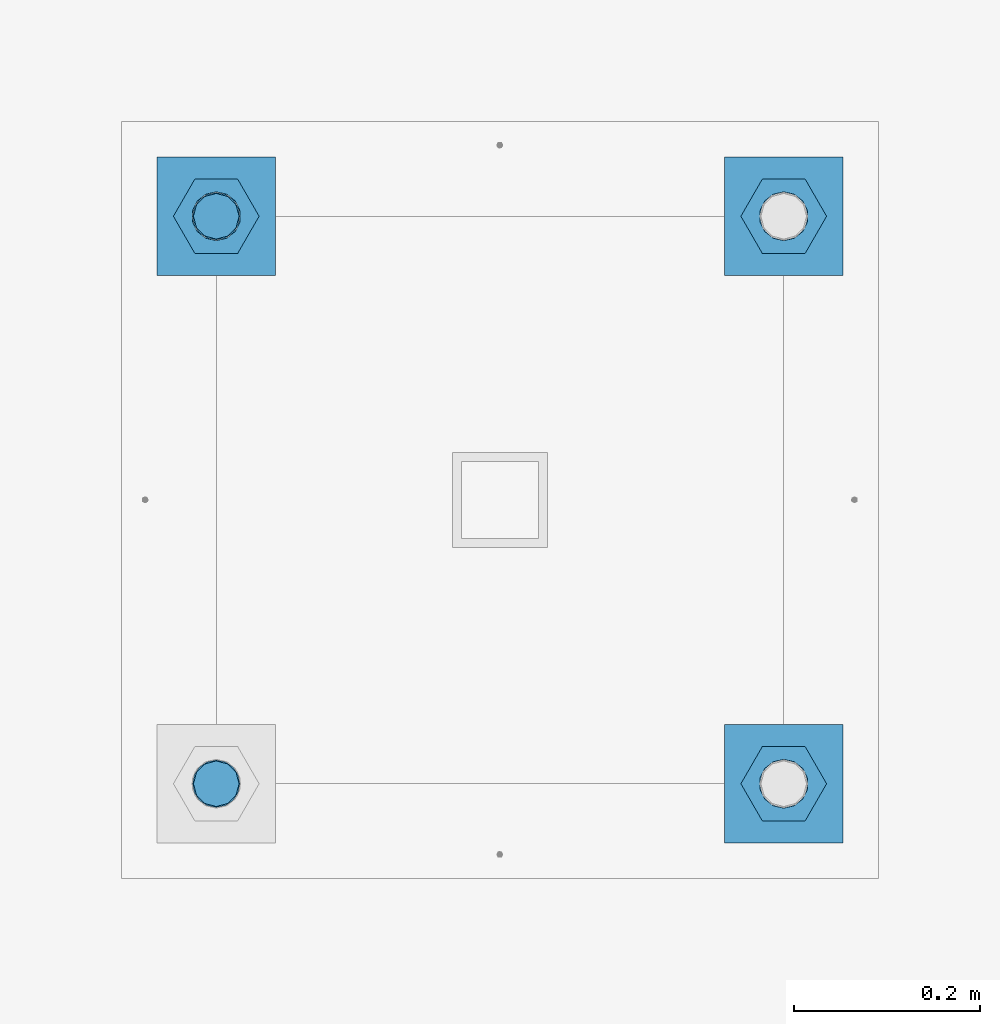
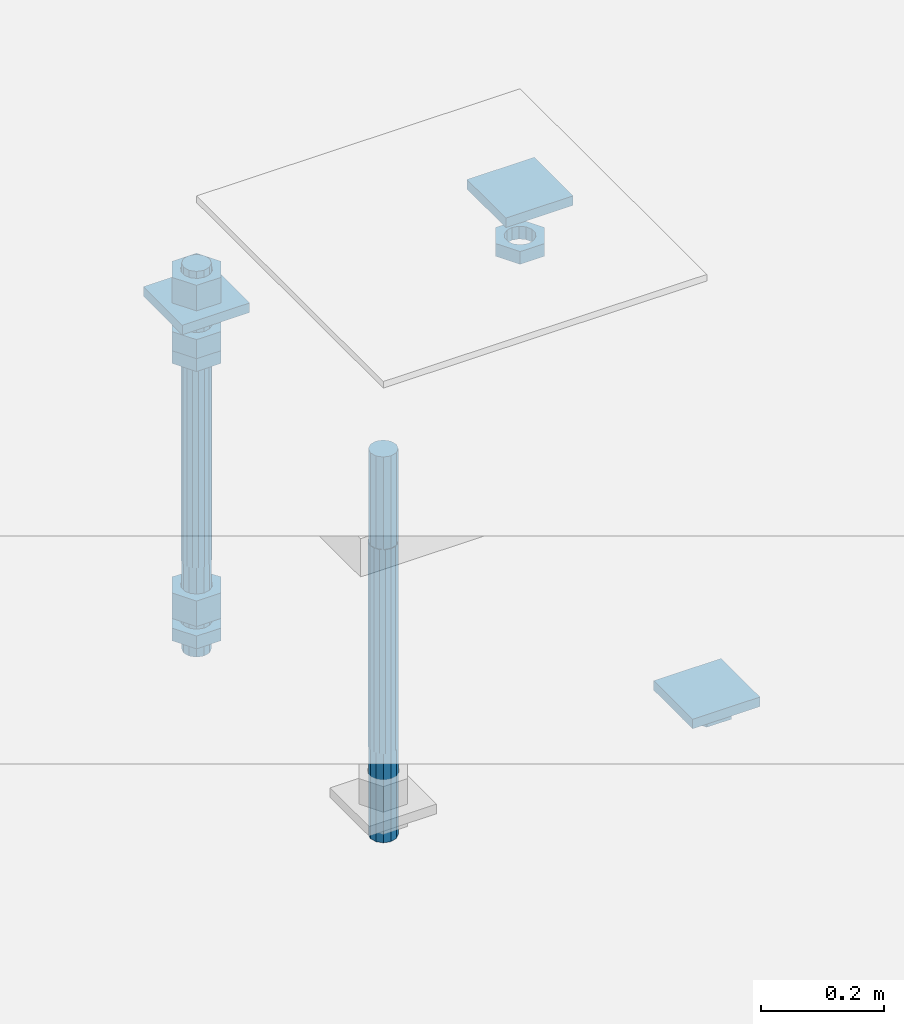
# One storey, part 2734 of 3843: 12 beams, 1 element without a shape of its own.
"""IFC2X3 building model written with IfcOpenShell, lengths in millimetres."""

from ifc_helpers import new_model, si_unit, frame, origin_with_axes, place, context, subcontext, project, spatial, faceted_brep, material, type_object, element, aggregate, save


model = new_model("IFC2X3")

# Units and contexts
model_context = context("Model", 3, precision=1e-05, world=origin_with_axes())
body_context = subcontext(model_context, "Body", "Model", "MODEL_VIEW")
ifc_project = project(units=[si_unit("LENGTHUNIT", "METRE", prefix="MILLI"), si_unit("AREAUNIT", "SQUARE_METRE"), si_unit("VOLUMEUNIT", "CUBIC_METRE"), si_unit("MASSUNIT", "GRAM", prefix="KILO"), si_unit("TIMEUNIT", "SECOND"), si_unit("PLANEANGLEUNIT", "RADIAN"), si_unit("SOLIDANGLEUNIT", "STERADIAN"), si_unit("THERMODYNAMICTEMPERATUREUNIT", "DEGREE_CELSIUS"), si_unit("LUMINOUSINTENSITYUNIT", "LUMEN")], contexts=[model_context])

# Site, building, storey
site_placement = place(None, origin_with_axes())
site = spatial("IfcSite", under=ifc_project, at=site_placement, CompositionType="ELEMENT")
building_placement = place(site_placement, origin_with_axes())
building = spatial("IfcBuilding", under=site, at=building_placement, Name="Undefined", CompositionType="ELEMENT")
storey_placement = place(building_placement, origin_with_axes())
storey = spatial("IfcBuildingStorey", under=building, at=storey_placement, Name="Undefined", CompositionType="ELEMENT", Elevation=0.0)

# Assembly, beams
assembly_placement = place(storey_placement, origin_with_axes())
assembly = element("IfcElementAssembly", 1, at=assembly_placement, inside=storey, Name="TEMPLATE", AssemblyPlace="NOTDEFINED", PredefinedType="RIGID_FRAME")
ifc_material_1 = material(Name="STEEL/A36")
beam_type_1 = type_object("IfcBeamType", PredefinedType="NOTDEFINED")
beam_1_placement = place(assembly_placement, frame((115798.6, 38798.5000015259, 29873.575), z_axis=(1.0, 0.0, 0.0), x_axis=(0.0, 1.0, 0.0)))
beam_1 = element("IfcBeam", 2, at=beam_1_placement, type_object=beam_type_1, material=ifc_material_1, Name="WASHER_PLATE", context=body_context, shape_type="Brep", body=[
    faceted_brep([(0.0, 9.52500000000146, -63.5), (0.0, 9.52500000000146, 63.5), (127.0, 9.52500000000146, 63.5), (127.0, 9.52500000000146, -63.5), (0.0, -9.52500000000146, 63.5), (127.0, -9.52500000000146, 63.5), (0.0, -9.52500000000146, -63.5), (127.0, -9.52500000000146, -63.5)], [[[0, 1, 2, 3]], [[1, 4, 5, 2]], [[4, 6, 7, 5]], [[6, 0, 3, 7]], [[5, 7, 3, 2]], [[6, 4, 1, 0]]]),
])
beam_2_placement = place(assembly_placement, frame((116408.2, 38798.5000015259, 29873.575), z_axis=(1.0, 0.0, 0.0), x_axis=(0.0, 1.0, 0.0)))
beam_2 = element("IfcBeam", 3, at=beam_2_placement, type_object=beam_type_1, material=ifc_material_1, Name="WASHER_PLATE", context=body_context, shape_type="Brep", body=[
    faceted_brep([(0.0, 9.52500000000146, -63.5), (0.0, 9.52500000000146, 63.5), (127.0, 9.52500000000146, 63.5), (127.0, 9.52500000000146, -63.5), (0.0, -9.52500000000146, 63.5), (127.0, -9.52500000000146, 63.5), (0.0, -9.52500000000146, -63.5), (127.0, -9.52500000000146, -63.5)], [[[0, 1, 2, 3]], [[1, 4, 5, 2]], [[4, 6, 7, 5]], [[6, 0, 3, 7]], [[5, 7, 3, 2]], [[6, 4, 1, 0]]]),
])
beam_3_placement = place(assembly_placement, frame((116408.2, 38188.9000015259, 29244.925), z_axis=(1.0, 0.0, 0.0), x_axis=(0.0, 1.0, 0.0)))
beam_3 = element("IfcBeam", 4, at=beam_3_placement, type_object=beam_type_1, material=ifc_material_1, Name="WASHER_PLATE", context=body_context, shape_type="Brep", body=[
    faceted_brep([(0.0, 9.52500000000146, -63.5), (0.0, 9.52500000000146, 63.5), (127.0, 9.52500000000146, 63.5), (127.0, 9.52500000000146, -63.5), (0.0, -9.52500000000146, 63.5), (127.0, -9.52500000000146, 63.5), (0.0, -9.52500000000146, -63.5), (127.0, -9.52500000000146, -63.5)], [[[0, 1, 2, 3]], [[1, 4, 5, 2]], [[4, 6, 7, 5]], [[6, 0, 3, 7]], [[5, 7, 3, 2]], [[6, 4, 1, 0]]]),
])
beam_type_2 = type_object("IfcBeamType", Name="2_HALF_NUT", PredefinedType="NOTDEFINED")
beam_4_placement = place(assembly_placement, frame((115798.6, 38862.0000015259, 29787.85), z_axis=(0.0, 1.0, 0.0), x_axis=(0.0, 0.0, -1.0)))
beam_4 = element("IfcBeam", 5, at=beam_4_placement, type_object=beam_type_2, material=ifc_material_1, Name="NUT", ObjectType="2_HALF_NUT", context=body_context, shape_type="Brep", body=[
    faceted_brep([(0.0, -46.0369987487793, 0.0), (0.0, -23.0184993743896, -39.869213104248), (25.4000000000015, -23.0184993743896, -39.869213104248), (25.4000000000015, -46.0369987487793, 0.0), (0.0, 23.0184993743896, -39.869213104248), (25.4000000000015, 23.0184993743896, -39.869213104248), (0.0, 46.0369987487793, 0.0), (25.4000000000015, 46.0369987487793, 0.0), (0.0, 23.0184993743896, 39.869213104248), (25.4000000000015, 23.0184993743896, 39.869213104248), (0.0, -23.0184993743896, 39.869213104248), (25.4000000000015, -23.0184993743896, 39.869213104248), (0.0, 0.0, 26.1940002441406), (0.0, 11.3650617044477, 23.5999013092805), (25.4000000000015, 11.3650617044477, 23.5999013092805), (25.4000000000015, 0.0, 26.1940002441406), (0.0, 20.4791109456419, 16.3316083006721), (25.4000000000015, 20.4791109456419, 16.3316083006721), (0.0, 25.5370200498292, 5.82867859874386), (25.4000000000015, 25.5370200498292, 5.82867859874386), (0.0, 25.5370200498292, -5.82867859874386), (25.4000000000015, 25.5370200498292, -5.82867859874386), (0.0, 20.4791109456419, -16.3316083006721), (25.4000000000015, 20.4791109456419, -16.3316083006721), (0.0, 11.3650617044477, -23.5999013092805), (25.4000000000015, 11.3650617044477, -23.5999013092805), (0.0, 0.0, -26.1940002441406), (25.4000000000015, 0.0, -26.1940002441406), (0.0, -11.3650617044477, -23.5999013092805), (25.4000000000015, -11.3650617044477, -23.5999013092805), (0.0, -20.4791109456419, -16.3316083006721), (25.4000000000015, -20.4791109456419, -16.3316083006721), (0.0, -25.5370200498292, -5.82867859874386), (25.4000000000015, -25.5370200498292, -5.82867859874386), (0.0, -25.5370200498292, 5.82867859874386), (25.4000000000015, -25.5370200498292, 5.82867859874386), (0.0, -20.4791109456419, 16.3316083006721), (25.4000000000015, -20.4791109456419, 16.3316083006721), (0.0, -11.3650617044477, 23.5999013092805), (25.4000000000015, -11.3650617044477, 23.5999013092805)], [[[0, 1, 2, 3]], [[1, 4, 5, 2]], [[4, 6, 7, 5]], [[6, 8, 9, 7]], [[8, 10, 11, 9]], [[10, 0, 3, 11]], [[12, 13, 14, 15]], [[13, 16, 17, 14]], [[16, 18, 19, 17]], [[18, 20, 21, 19]], [[20, 22, 23, 21]], [[22, 24, 25, 23]], [[24, 26, 27, 25]], [[26, 28, 29, 27]], [[28, 30, 31, 29]], [[30, 32, 33, 31]], [[32, 34, 35, 33]], [[34, 36, 37, 35]], [[36, 38, 39, 37]], [[38, 12, 15, 39]], [[5, 7, 9, 11, 3, 2], [17, 19, 21, 23, 25, 27, 29, 31, 33, 35, 37, 39, 15, 14]], [[10, 8, 6, 4, 1, 0], [38, 36, 34, 32, 30, 28, 26, 24, 22, 20, 18, 16, 13, 12]]]),
])
beam_5_placement = place(assembly_placement, frame((116408.2, 38862.0000015259, 29787.85), z_axis=(0.0, 1.0, 0.0), x_axis=(0.0, 0.0, -1.0)))
beam_5 = element("IfcBeam", 6, at=beam_5_placement, type_object=beam_type_2, material=ifc_material_1, Name="NUT", ObjectType="2_HALF_NUT", context=body_context, shape_type="Brep", body=[
    faceted_brep([(0.0, -46.0369987487793, 0.0), (0.0, -23.0184993743896, -39.869213104248), (25.4000000000015, -23.0184993743896, -39.869213104248), (25.4000000000015, -46.0369987487793, 0.0), (0.0, 23.0184993743896, -39.869213104248), (25.4000000000015, 23.0184993743896, -39.869213104248), (0.0, 46.0369987487793, 0.0), (25.4000000000015, 46.0369987487793, 0.0), (0.0, 23.0184993743896, 39.869213104248), (25.4000000000015, 23.0184993743896, 39.869213104248), (0.0, -23.0184993743896, 39.869213104248), (25.4000000000015, -23.0184993743896, 39.869213104248), (0.0, 0.0, 26.1940002441406), (0.0, 11.3650617044477, 23.5999013092805), (25.4000000000015, 11.3650617044477, 23.5999013092805), (25.4000000000015, 0.0, 26.1940002441406), (0.0, 20.4791109456419, 16.3316083006721), (25.4000000000015, 20.4791109456419, 16.3316083006721), (0.0, 25.5370200498292, 5.82867859874386), (25.4000000000015, 25.5370200498292, 5.82867859874386), (0.0, 25.5370200498292, -5.82867859874386), (25.4000000000015, 25.5370200498292, -5.82867859874386), (0.0, 20.4791109456419, -16.3316083006721), (25.4000000000015, 20.4791109456419, -16.3316083006721), (0.0, 11.3650617044477, -23.5999013092805), (25.4000000000015, 11.3650617044477, -23.5999013092805), (0.0, 0.0, -26.1940002441406), (25.4000000000015, 0.0, -26.1940002441406), (0.0, -11.3650617044477, -23.5999013092805), (25.4000000000015, -11.3650617044477, -23.5999013092805), (0.0, -20.4791109456419, -16.3316083006721), (25.4000000000015, -20.4791109456419, -16.3316083006721), (0.0, -25.5370200498292, -5.82867859874386), (25.4000000000015, -25.5370200498292, -5.82867859874386), (0.0, -25.5370200498292, 5.82867859874386), (25.4000000000015, -25.5370200498292, 5.82867859874386), (0.0, -20.4791109456419, 16.3316083006721), (25.4000000000015, -20.4791109456419, 16.3316083006721), (0.0, -11.3650617044477, 23.5999013092805), (25.4000000000015, -11.3650617044477, 23.5999013092805)], [[[0, 1, 2, 3]], [[1, 4, 5, 2]], [[4, 6, 7, 5]], [[6, 8, 9, 7]], [[8, 10, 11, 9]], [[10, 0, 3, 11]], [[12, 13, 14, 15]], [[13, 16, 17, 14]], [[16, 18, 19, 17]], [[18, 20, 21, 19]], [[20, 22, 23, 21]], [[22, 24, 25, 23]], [[24, 26, 27, 25]], [[26, 28, 29, 27]], [[28, 30, 31, 29]], [[30, 32, 33, 31]], [[32, 34, 35, 33]], [[34, 36, 37, 35]], [[36, 38, 39, 37]], [[38, 12, 15, 39]], [[5, 7, 9, 11, 3, 2], [17, 19, 21, 23, 25, 27, 29, 31, 33, 35, 37, 39, 15, 14]], [[10, 8, 6, 4, 1, 0], [38, 36, 34, 32, 30, 28, 26, 24, 22, 20, 18, 16, 13, 12]]]),
])
beam_6_placement = place(assembly_placement, frame((116408.2, 38252.4000015259, 29235.4), z_axis=(0.0, 1.0, 0.0), x_axis=(0.0, 0.0, -1.0)))
beam_6 = element("IfcBeam", 7, at=beam_6_placement, type_object=beam_type_2, material=ifc_material_1, Name="NUT", ObjectType="2_HALF_NUT", context=body_context, shape_type="Brep", body=[
    faceted_brep([(0.0, -46.0369987487793, 0.0), (0.0, -23.0184993743896, -39.869213104248), (25.4000000000015, -23.0184993743896, -39.869213104248), (25.4000000000015, -46.0369987487793, 0.0), (0.0, 23.0184993743896, -39.869213104248), (25.4000000000015, 23.0184993743896, -39.869213104248), (0.0, 46.0369987487793, 0.0), (25.4000000000015, 46.0369987487793, 0.0), (0.0, 23.0184993743896, 39.869213104248), (25.4000000000015, 23.0184993743896, 39.869213104248), (0.0, -23.0184993743896, 39.869213104248), (25.4000000000015, -23.0184993743896, 39.869213104248), (0.0, 0.0, 26.1940002441406), (0.0, 11.3650617044477, 23.5999013092805), (25.4000000000015, 11.3650617044477, 23.5999013092805), (25.4000000000015, 0.0, 26.1940002441406), (0.0, 20.4791109456419, 16.3316083006721), (25.4000000000015, 20.4791109456419, 16.3316083006721), (0.0, 25.5370200498292, 5.82867859874386), (25.4000000000015, 25.5370200498292, 5.82867859874386), (0.0, 25.5370200498292, -5.82867859874386), (25.4000000000015, 25.5370200498292, -5.82867859874386), (0.0, 20.4791109456419, -16.3316083006721), (25.4000000000015, 20.4791109456419, -16.3316083006721), (0.0, 11.3650617044477, -23.5999013092805), (25.4000000000015, 11.3650617044477, -23.5999013092805), (0.0, 0.0, -26.1940002441406), (25.4000000000015, 0.0, -26.1940002441406), (0.0, -11.3650617044477, -23.5999013092805), (25.4000000000015, -11.3650617044477, -23.5999013092805), (0.0, -20.4791109456419, -16.3316083006721), (25.4000000000015, -20.4791109456419, -16.3316083006721), (0.0, -25.5370200498292, -5.82867859874386), (25.4000000000015, -25.5370200498292, -5.82867859874386), (0.0, -25.5370200498292, 5.82867859874386), (25.4000000000015, -25.5370200498292, 5.82867859874386), (0.0, -20.4791109456419, 16.3316083006721), (25.4000000000015, -20.4791109456419, 16.3316083006721), (0.0, -11.3650617044477, 23.5999013092805), (25.4000000000015, -11.3650617044477, 23.5999013092805)], [[[0, 1, 2, 3]], [[1, 4, 5, 2]], [[4, 6, 7, 5]], [[6, 8, 9, 7]], [[8, 10, 11, 9]], [[10, 0, 3, 11]], [[12, 13, 14, 15]], [[13, 16, 17, 14]], [[16, 18, 19, 17]], [[18, 20, 21, 19]], [[20, 22, 23, 21]], [[22, 24, 25, 23]], [[24, 26, 27, 25]], [[26, 28, 29, 27]], [[28, 30, 31, 29]], [[30, 32, 33, 31]], [[32, 34, 35, 33]], [[34, 36, 37, 35]], [[36, 38, 39, 37]], [[38, 12, 15, 39]], [[5, 7, 9, 11, 3, 2], [17, 19, 21, 23, 25, 27, 29, 31, 33, 35, 37, 39, 15, 14]], [[10, 8, 6, 4, 1, 0], [38, 36, 34, 32, 30, 28, 26, 24, 22, 20, 18, 16, 13, 12]]]),
])
beam_7_placement = place(assembly_placement, frame((115798.6, 38862.0000015259, 29235.4), z_axis=(0.0, 1.0, 0.0), x_axis=(0.0, 0.0, -1.0)))
beam_7 = element("IfcBeam", 8, at=beam_7_placement, type_object=beam_type_2, material=ifc_material_1, Name="NUT", ObjectType="2_HALF_NUT", context=body_context, shape_type="Brep", body=[
    faceted_brep([(0.0, -46.0369987487793, 0.0), (0.0, -23.0184993743896, -39.869213104248), (25.4000000000015, -23.0184993743896, -39.869213104248), (25.4000000000015, -46.0369987487793, 0.0), (0.0, 23.0184993743896, -39.869213104248), (25.4000000000015, 23.0184993743896, -39.869213104248), (0.0, 46.0369987487793, 0.0), (25.4000000000015, 46.0369987487793, 0.0), (0.0, 23.0184993743896, 39.869213104248), (25.4000000000015, 23.0184993743896, 39.869213104248), (0.0, -23.0184993743896, 39.869213104248), (25.4000000000015, -23.0184993743896, 39.869213104248), (0.0, 0.0, 26.1940002441406), (0.0, 11.3650617044477, 23.5999013092805), (25.4000000000015, 11.3650617044477, 23.5999013092805), (25.4000000000015, 0.0, 26.1940002441406), (0.0, 20.4791109456419, 16.3316083006721), (25.4000000000015, 20.4791109456419, 16.3316083006721), (0.0, 25.5370200498292, 5.82867859874386), (25.4000000000015, 25.5370200498292, 5.82867859874386), (0.0, 25.5370200498292, -5.82867859874386), (25.4000000000015, 25.5370200498292, -5.82867859874386), (0.0, 20.4791109456419, -16.3316083006721), (25.4000000000015, 20.4791109456419, -16.3316083006721), (0.0, 11.3650617044477, -23.5999013092805), (25.4000000000015, 11.3650617044477, -23.5999013092805), (0.0, 0.0, -26.1940002441406), (25.4000000000015, 0.0, -26.1940002441406), (0.0, -11.3650617044477, -23.5999013092805), (25.4000000000015, -11.3650617044477, -23.5999013092805), (0.0, -20.4791109456419, -16.3316083006721), (25.4000000000015, -20.4791109456419, -16.3316083006721), (0.0, -25.5370200498292, -5.82867859874386), (25.4000000000015, -25.5370200498292, -5.82867859874386), (0.0, -25.5370200498292, 5.82867859874386), (25.4000000000015, -25.5370200498292, 5.82867859874386), (0.0, -20.4791109456419, 16.3316083006721), (25.4000000000015, -20.4791109456419, 16.3316083006721), (0.0, -11.3650617044477, 23.5999013092805), (25.4000000000015, -11.3650617044477, 23.5999013092805)], [[[0, 1, 2, 3]], [[1, 4, 5, 2]], [[4, 6, 7, 5]], [[6, 8, 9, 7]], [[8, 10, 11, 9]], [[10, 0, 3, 11]], [[12, 13, 14, 15]], [[13, 16, 17, 14]], [[16, 18, 19, 17]], [[18, 20, 21, 19]], [[20, 22, 23, 21]], [[22, 24, 25, 23]], [[24, 26, 27, 25]], [[26, 28, 29, 27]], [[28, 30, 31, 29]], [[30, 32, 33, 31]], [[32, 34, 35, 33]], [[34, 36, 37, 35]], [[36, 38, 39, 37]], [[38, 12, 15, 39]], [[5, 7, 9, 11, 3, 2], [17, 19, 21, 23, 25, 27, 29, 31, 33, 35, 37, 39, 15, 14]], [[10, 8, 6, 4, 1, 0], [38, 36, 34, 32, 30, 28, 26, 24, 22, 20, 18, 16, 13, 12]]]),
])
beam_type_3 = type_object("IfcBeamType", Name="2_HEAVY_HEX_NUT", PredefinedType="NOTDEFINED")
beam_8_placement = place(assembly_placement, frame((115798.6, 38862.0000015259, 29825.95), z_axis=(0.0, 1.0, 0.0), x_axis=(0.0, 0.0, -1.0)))
beam_8 = element("IfcBeam", 9, at=beam_8_placement, type_object=beam_type_3, material=ifc_material_1, Name="NUT", ObjectType="2_HEAVY_HEX_NUT", context=body_context, shape_type="Brep", body=[
    faceted_brep([(0.0, -46.0369987487793, 0.0), (0.0, -23.0184993743896, -39.869213104248), (38.0999999999985, -23.0184993743896, -39.869213104248), (38.0999999999985, -46.0369987487793, 0.0), (0.0, 23.0184993743896, -39.869213104248), (38.0999999999985, 23.0184993743896, -39.869213104248), (0.0, 46.0369987487793, 0.0), (38.0999999999985, 46.0369987487793, 0.0), (0.0, 23.0184993743896, 39.869213104248), (38.0999999999985, 23.0184993743896, 39.869213104248), (0.0, -23.0184993743896, 39.869213104248), (38.0999999999985, -23.0184993743896, 39.869213104248), (0.0, 0.0, 26.1940002441406), (0.0, 11.3650617044477, 23.5999013092805), (38.0999999999985, 11.3650617044477, 23.5999013092805), (38.0999999999985, 0.0, 26.1940002441406), (0.0, 20.4791109456419, 16.3316083006721), (38.0999999999985, 20.4791109456419, 16.3316083006721), (0.0, 25.5370200498292, 5.82867859874386), (38.0999999999985, 25.5370200498292, 5.82867859874386), (0.0, 25.5370200498292, -5.82867859874386), (38.0999999999985, 25.5370200498292, -5.82867859874386), (0.0, 20.4791109456419, -16.3316083006721), (38.0999999999985, 20.4791109456419, -16.3316083006721), (0.0, 11.3650617044477, -23.5999013092805), (38.0999999999985, 11.3650617044477, -23.5999013092805), (0.0, 0.0, -26.1940002441406), (38.0999999999985, 0.0, -26.1940002441406), (0.0, -11.3650617044477, -23.5999013092805), (38.0999999999985, -11.3650617044477, -23.5999013092805), (0.0, -20.4791109456419, -16.3316083006721), (38.0999999999985, -20.4791109456419, -16.3316083006721), (0.0, -25.5370200498292, -5.82867859874386), (38.0999999999985, -25.5370200498292, -5.82867859874386), (0.0, -25.5370200498292, 5.82867859874386), (38.0999999999985, -25.5370200498292, 5.82867859874386), (0.0, -20.4791109456419, 16.3316083006721), (38.0999999999985, -20.4791109456419, 16.3316083006721), (0.0, -11.3650617044477, 23.5999013092805), (38.0999999999985, -11.3650617044477, 23.5999013092805)], [[[0, 1, 2, 3]], [[1, 4, 5, 2]], [[4, 6, 7, 5]], [[6, 8, 9, 7]], [[8, 10, 11, 9]], [[10, 0, 3, 11]], [[12, 13, 14, 15]], [[13, 16, 17, 14]], [[16, 18, 19, 17]], [[18, 20, 21, 19]], [[20, 22, 23, 21]], [[22, 24, 25, 23]], [[24, 26, 27, 25]], [[26, 28, 29, 27]], [[28, 30, 31, 29]], [[30, 32, 33, 31]], [[32, 34, 35, 33]], [[34, 36, 37, 35]], [[36, 38, 39, 37]], [[38, 12, 15, 39]], [[5, 7, 9, 11, 3, 2], [17, 19, 21, 23, 25, 27, 29, 31, 33, 35, 37, 39, 15, 14]], [[10, 8, 6, 4, 1, 0], [38, 36, 34, 32, 30, 28, 26, 24, 22, 20, 18, 16, 13, 12]]]),
])
beam_9_placement = place(assembly_placement, frame((115798.6, 38862.0000015259, 29933.9), z_axis=(0.0, 1.0, 0.0), x_axis=(0.0, 0.0, -1.0)))
beam_9 = element("IfcBeam", 10, at=beam_9_placement, type_object=beam_type_3, material=ifc_material_1, Name="NUT", ObjectType="2_HEAVY_HEX_NUT", context=body_context, shape_type="Brep", body=[
    faceted_brep([(0.0, -46.0369987487793, 0.0), (0.0, -23.0184993743896, -39.869213104248), (50.7999999999993, -23.0184993743896, -39.869213104248), (50.7999999999993, -46.0369987487793, 0.0), (0.0, 23.0184993743896, -39.869213104248), (50.7999999999993, 23.0184993743896, -39.869213104248), (0.0, 46.0369987487793, 0.0), (50.7999999999993, 46.0369987487793, 0.0), (0.0, 23.0184993743896, 39.869213104248), (50.7999999999993, 23.0184993743896, 39.869213104248), (0.0, -23.0184993743896, 39.869213104248), (50.7999999999993, -23.0184993743896, 39.869213104248), (0.0, 0.0, 26.1940002441406), (0.0, 11.3650617044477, 23.5999013092805), (50.7999999999993, 11.3650617044477, 23.5999013092805), (50.7999999999993, 0.0, 26.1940002441406), (0.0, 20.4791109456419, 16.3316083006721), (50.7999999999993, 20.4791109456419, 16.3316083006721), (0.0, 25.5370200498292, 5.82867859874386), (50.7999999999993, 25.5370200498292, 5.82867859874386), (0.0, 25.5370200498292, -5.82867859874386), (50.7999999999993, 25.5370200498292, -5.82867859874386), (0.0, 20.4791109456419, -16.3316083006721), (50.7999999999993, 20.4791109456419, -16.3316083006721), (0.0, 11.3650617044477, -23.5999013092805), (50.7999999999993, 11.3650617044477, -23.5999013092805), (0.0, 0.0, -26.1940002441406), (50.7999999999993, 0.0, -26.1940002441406), (0.0, -11.3650617044477, -23.5999013092805), (50.7999999999993, -11.3650617044477, -23.5999013092805), (0.0, -20.4791109456419, -16.3316083006721), (50.7999999999993, -20.4791109456419, -16.3316083006721), (0.0, -25.5370200498292, -5.82867859874386), (50.7999999999993, -25.5370200498292, -5.82867859874386), (0.0, -25.5370200498292, 5.82867859874386), (50.7999999999993, -25.5370200498292, 5.82867859874386), (0.0, -20.4791109456419, 16.3316083006721), (50.7999999999993, -20.4791109456419, 16.3316083006721), (0.0, -11.3650617044477, 23.5999013092805), (50.7999999999993, -11.3650617044477, 23.5999013092805)], [[[0, 1, 2, 3]], [[1, 4, 5, 2]], [[4, 6, 7, 5]], [[6, 8, 9, 7]], [[8, 10, 11, 9]], [[10, 0, 3, 11]], [[12, 13, 14, 15]], [[13, 16, 17, 14]], [[16, 18, 19, 17]], [[18, 20, 21, 19]], [[20, 22, 23, 21]], [[22, 24, 25, 23]], [[24, 26, 27, 25]], [[26, 28, 29, 27]], [[28, 30, 31, 29]], [[30, 32, 33, 31]], [[32, 34, 35, 33]], [[34, 36, 37, 35]], [[36, 38, 39, 37]], [[38, 12, 15, 39]], [[5, 7, 9, 11, 3, 2], [17, 19, 21, 23, 25, 27, 29, 31, 33, 35, 37, 39, 15, 14]], [[10, 8, 6, 4, 1, 0], [38, 36, 34, 32, 30, 28, 26, 24, 22, 20, 18, 16, 13, 12]]]),
])
beam_10_placement = place(assembly_placement, frame((115798.6, 38862.0000015259, 29305.25), z_axis=(0.0, 1.0, 0.0), x_axis=(0.0, 0.0, -1.0)))
beam_10 = element("IfcBeam", 11, at=beam_10_placement, type_object=beam_type_3, material=ifc_material_1, Name="NUT", ObjectType="2_HEAVY_HEX_NUT", context=body_context, shape_type="Brep", body=[
    faceted_brep([(0.0, -46.0369987487793, 0.0), (0.0, -23.0184993743896, -39.869213104248), (50.7999999999993, -23.0184993743896, -39.869213104248), (50.7999999999993, -46.0369987487793, 0.0), (0.0, 23.0184993743896, -39.869213104248), (50.7999999999993, 23.0184993743896, -39.869213104248), (0.0, 46.0369987487793, 0.0), (50.7999999999993, 46.0369987487793, 0.0), (0.0, 23.0184993743896, 39.869213104248), (50.7999999999993, 23.0184993743896, 39.869213104248), (0.0, -23.0184993743896, 39.869213104248), (50.7999999999993, -23.0184993743896, 39.869213104248), (0.0, 0.0, 26.1940002441406), (0.0, 11.3650617044477, 23.5999013092805), (50.7999999999993, 11.3650617044477, 23.5999013092805), (50.7999999999993, 0.0, 26.1940002441406), (0.0, 20.4791109456419, 16.3316083006721), (50.7999999999993, 20.4791109456419, 16.3316083006721), (0.0, 25.5370200498292, 5.82867859874386), (50.7999999999993, 25.5370200498292, 5.82867859874386), (0.0, 25.5370200498292, -5.82867859874386), (50.7999999999993, 25.5370200498292, -5.82867859874386), (0.0, 20.4791109456419, -16.3316083006721), (50.7999999999993, 20.4791109456419, -16.3316083006721), (0.0, 11.3650617044477, -23.5999013092805), (50.7999999999993, 11.3650617044477, -23.5999013092805), (0.0, 0.0, -26.1940002441406), (50.7999999999993, 0.0, -26.1940002441406), (0.0, -11.3650617044477, -23.5999013092805), (50.7999999999993, -11.3650617044477, -23.5999013092805), (0.0, -20.4791109456419, -16.3316083006721), (50.7999999999993, -20.4791109456419, -16.3316083006721), (0.0, -25.5370200498292, -5.82867859874386), (50.7999999999993, -25.5370200498292, -5.82867859874386), (0.0, -25.5370200498292, 5.82867859874386), (50.7999999999993, -25.5370200498292, 5.82867859874386), (0.0, -20.4791109456419, 16.3316083006721), (50.7999999999993, -20.4791109456419, 16.3316083006721), (0.0, -11.3650617044477, 23.5999013092805), (50.7999999999993, -11.3650617044477, 23.5999013092805)], [[[0, 1, 2, 3]], [[1, 4, 5, 2]], [[4, 6, 7, 5]], [[6, 8, 9, 7]], [[8, 10, 11, 9]], [[10, 0, 3, 11]], [[12, 13, 14, 15]], [[13, 16, 17, 14]], [[16, 18, 19, 17]], [[18, 20, 21, 19]], [[20, 22, 23, 21]], [[22, 24, 25, 23]], [[24, 26, 27, 25]], [[26, 28, 29, 27]], [[28, 30, 31, 29]], [[30, 32, 33, 31]], [[32, 34, 35, 33]], [[34, 36, 37, 35]], [[36, 38, 39, 37]], [[38, 12, 15, 39]], [[5, 7, 9, 11, 3, 2], [17, 19, 21, 23, 25, 27, 29, 31, 33, 35, 37, 39, 15, 14]], [[10, 8, 6, 4, 1, 0], [38, 36, 34, 32, 30, 28, 26, 24, 22, 20, 18, 16, 13, 12]]]),
])
ifc_material_2 = material()
beam_type_4 = type_object("IfcBeamType", PredefinedType="NOTDEFINED")
beam_11_placement = place(assembly_placement, frame((115798.6, 38862.0000015259, 29762.45), z_axis=(0.0, 1.0, 0.0), x_axis=(0.0, 0.0, -1.0)))
beam_11 = element("IfcBeam", 12, at=beam_11_placement, type_object=beam_type_4, material=ifc_material_2, Name="ANCHOR_ROD", context=body_context, shape_type="Brep", body=[
    faceted_brep([(-184.150000000001, -21.217622392709, 12.25), (-184.150000000001, -12.2499999999854, 21.2176223927163), (-184.150000000001, 1.45519152283669e-11, 24.5), (-184.150000000001, 12.2500000000146, 21.2176223927163), (-184.150000000001, 21.2176223927381, 12.25), (-184.150000000001, 24.5000000000146, 0.0), (-184.150000000001, 21.2176223927381, -12.25), (-184.150000000001, 12.2500000000146, -21.2176223927163), (-184.150000000001, 1.45519152283669e-11, -24.5), (-184.150000000001, -12.2499999999854, -21.2176223927163), (-184.150000000001, -21.217622392709, -12.25), (-184.150000000001, -24.4999999999854, 0.0), (0.0, 24.5000000000146, 0.0), (0.0, 21.2176223927381, -12.25), (0.0, 12.2500000000146, -21.2176223927163), (0.0, 1.45519152283669e-11, -24.5), (0.0, -12.2499999999854, -21.2176223927163), (0.0, -21.217622392709, -12.25), (0.0, -24.4999999999854, 0.0), (0.0, -21.217622392709, 12.25), (0.0, -12.2499999999854, 21.2176223927163), (0.0, 1.45519152283669e-11, 24.5), (0.0, 12.2500000000146, 21.2176223927163), (0.0, 21.2176223927381, 12.25), (0.0, -23.4665401257807, 9.72015918207035), (0.0, -17.9605122421344, 17.9605122421417), (0.0, -9.72015918207762, 23.466540125788), (0.0, 0.0, 25.4000000000015), (0.0, 9.72015918207762, 23.466540125788), (0.0, 17.9605122421344, 17.9605122421417), (0.0, 23.4665401257807, 9.72015918207035), (0.0, 25.3999996185303, 0.0), (0.0, 23.4665401257807, -9.72015918207035), (0.0, 17.9605122421344, -17.9605122421417), (0.0, 9.72015918207762, -23.466540125788), (0.0, 0.0, -25.4000000000015), (0.0, -9.72015918207762, -23.466540125788), (0.0, -17.9605122421344, -17.9605122421417), (0.0, -23.4665401257807, -9.72015918207035), (0.0, -25.3999996185303, 0.0), (406.399999999998, -25.3999999999942, 0.0), (406.399999999998, -23.4665401257807, 9.72015918207035), (406.399999999998, -17.9605122421344, 17.9605122421417), (406.399999999998, -9.72015918207762, 23.466540125788), (406.399999999998, 0.0, 25.4000000000015), (406.399999999998, 9.72015918207762, 23.466540125788), (406.399999999998, 17.9605122421344, 17.9605122421417), (406.399999999998, 23.4665401257807, 9.72015918207035), (406.399999999998, 25.3999999999942, 0.0), (406.399999999998, 23.4665401257807, -9.72015918207035), (406.399999999998, 17.9605122421344, -17.9605122421417), (406.399999999998, 9.72015918207762, -23.466540125788), (406.399999999998, 0.0, -25.4000000000015), (406.399999999998, -9.72015918207762, -23.466540125788), (406.399999999998, -17.9605122421344, -17.9605122421417), (406.399999999998, -23.4665401257807, -9.72015918207035), (406.399999999998, -12.2499999999854, 21.2176223927163), (406.399999999998, 1.45519152283669e-11, 24.5), (406.399999999998, 12.2500000000146, 21.2176223927163), (406.399999999998, 21.2176223927381, 12.25), (406.399999999998, 24.5000000000146, 0.0), (406.399999999998, 21.2176223927381, -12.25), (406.399999999998, 12.2500000000146, -21.2176223927163), (406.399999999998, 1.45519152283669e-11, -24.5), (406.399999999998, -12.2499999999854, -21.2176223927163), (406.399999999998, -21.217622392709, -12.25), (406.399999999998, -24.4999999999854, 0.0), (406.399999999998, -21.217622392709, 12.25), (584.200000000001, -12.2499999999854, -21.2176223927163), (584.200000000001, 1.45519152283669e-11, -24.5), (584.200000000001, 12.2500000000146, -21.2176223927163), (584.200000000001, 21.2176223927381, -12.25), (584.200000000001, 24.5000000000146, 0.0), (584.200000000001, 21.2176223927381, 12.25), (584.200000000001, 12.2500000000146, 21.2176223927163), (584.200000000001, 1.45519152283669e-11, 24.5), (584.200000000001, -12.2499999999854, 21.2176223927163), (584.200000000001, -21.217622392709, 12.25), (584.200000000001, -24.4999999999854, 0.0), (584.200000000001, -21.217622392709, -12.25)], [[[0, 1, 2, 3, 4, 5, 6, 7, 8, 9, 10, 11]], [[6, 5, 12, 13]], [[7, 6, 13, 14]], [[8, 7, 14, 15]], [[9, 8, 15, 16]], [[10, 9, 16, 17]], [[11, 10, 17, 18]], [[0, 11, 18, 19]], [[1, 0, 19, 20]], [[2, 1, 20, 21]], [[3, 2, 21, 22]], [[4, 3, 22, 23]], [[5, 4, 23, 12]], [[24, 25, 26, 27, 28, 29, 30, 31, 32, 33, 34, 35, 36, 37, 38, 39], [22, 21, 20, 19, 18, 17, 16, 15, 14, 13, 12, 23]], [[24, 39, 40, 41]], [[25, 24, 41, 42]], [[26, 25, 42, 43]], [[27, 26, 43, 44]], [[28, 27, 44, 45]], [[29, 28, 45, 46]], [[30, 29, 46, 47]], [[31, 30, 47, 48]], [[32, 31, 48, 49]], [[33, 32, 49, 50]], [[34, 33, 50, 51]], [[35, 34, 51, 52]], [[36, 35, 52, 53]], [[37, 36, 53, 54]], [[38, 37, 54, 55]], [[39, 38, 55, 40]], [[54, 53, 52, 51, 50, 49, 48, 47, 46, 45, 44, 43, 42, 41, 40, 55], [56, 57, 58, 59, 60, 61, 62, 63, 64, 65, 66, 67]], [[68, 69, 70, 71, 72, 73, 74, 75, 76, 77, 78, 79]], [[76, 75, 57, 56]], [[77, 76, 56, 67]], [[78, 77, 67, 66]], [[79, 78, 66, 65]], [[68, 79, 65, 64]], [[69, 68, 64, 63]], [[70, 69, 63, 62]], [[71, 70, 62, 61]], [[72, 71, 61, 60]], [[73, 72, 60, 59]], [[74, 73, 59, 58]], [[75, 74, 58, 57]]]),
])
beam_12_placement = place(assembly_placement, frame((115798.6, 38252.4000015259, 29762.45), z_axis=(0.0, 1.0, 0.0), x_axis=(0.0, 0.0, -1.0)))
beam_12 = element("IfcBeam", 13, at=beam_12_placement, type_object=beam_type_4, material=ifc_material_2, Name="ANCHOR_ROD", context=body_context, shape_type="Brep", body=[
    faceted_brep([(-184.150000000001, -21.217622392709, 12.25), (-184.150000000001, -12.2499999999854, 21.2176223927163), (-184.150000000001, 1.45519152283669e-11, 24.5), (-184.150000000001, 12.2500000000146, 21.2176223927163), (-184.150000000001, 21.2176223927381, 12.25), (-184.150000000001, 24.5000000000146, 0.0), (-184.150000000001, 21.2176223927381, -12.25), (-184.150000000001, 12.2500000000146, -21.2176223927163), (-184.150000000001, 1.45519152283669e-11, -24.5), (-184.150000000001, -12.2499999999854, -21.2176223927163), (-184.150000000001, -21.217622392709, -12.25), (-184.150000000001, -24.4999999999854, 0.0), (0.0, 24.5000000000146, 0.0), (0.0, 21.2176223927381, -12.25), (0.0, 12.2500000000146, -21.2176223927163), (0.0, 1.45519152283669e-11, -24.5), (0.0, -12.2499999999854, -21.2176223927163), (0.0, -21.217622392709, -12.25), (0.0, -24.4999999999854, 0.0), (0.0, -21.217622392709, 12.25), (0.0, -12.2499999999854, 21.2176223927163), (0.0, 1.45519152283669e-11, 24.5), (0.0, 12.2500000000146, 21.2176223927163), (0.0, 21.2176223927381, 12.25), (0.0, -23.4665401257807, 9.72015918207035), (0.0, -17.9605122421344, 17.9605122421417), (0.0, -9.72015918207762, 23.466540125788), (0.0, 0.0, 25.4000000000015), (0.0, 9.72015918207762, 23.466540125788), (0.0, 17.9605122421344, 17.9605122421417), (0.0, 23.4665401257807, 9.72015918207035), (0.0, 25.3999996185303, 0.0), (0.0, 23.4665401257807, -9.72015918207035), (0.0, 17.9605122421344, -17.9605122421417), (0.0, 9.72015918207762, -23.466540125788), (0.0, 0.0, -25.4000000000015), (0.0, -9.72015918207762, -23.466540125788), (0.0, -17.9605122421344, -17.9605122421417), (0.0, -23.4665401257807, -9.72015918207035), (0.0, -25.3999996185303, 0.0), (406.399999999998, -25.3999999999942, 0.0), (406.399999999998, -23.4665401257807, 9.72015918207035), (406.399999999998, -17.9605122421344, 17.9605122421417), (406.399999999998, -9.72015918207762, 23.466540125788), (406.399999999998, 0.0, 25.4000000000015), (406.399999999998, 9.72015918207762, 23.466540125788), (406.399999999998, 17.9605122421344, 17.9605122421417), (406.399999999998, 23.4665401257807, 9.72015918207035), (406.399999999998, 25.3999999999942, 0.0), (406.399999999998, 23.4665401257807, -9.72015918207035), (406.399999999998, 17.9605122421344, -17.9605122421417), (406.399999999998, 9.72015918207762, -23.466540125788), (406.399999999998, 0.0, -25.4000000000015), (406.399999999998, -9.72015918207762, -23.466540125788), (406.399999999998, -17.9605122421344, -17.9605122421417), (406.399999999998, -23.4665401257807, -9.72015918207035), (406.399999999998, -12.2499999999854, 21.2176223927163), (406.399999999998, 1.45519152283669e-11, 24.5), (406.399999999998, 12.2500000000146, 21.2176223927163), (406.399999999998, 21.2176223927381, 12.25), (406.399999999998, 24.5000000000146, 0.0), (406.399999999998, 21.2176223927381, -12.25), (406.399999999998, 12.2500000000146, -21.2176223927163), (406.399999999998, 1.45519152283669e-11, -24.5), (406.399999999998, -12.2499999999854, -21.2176223927163), (406.399999999998, -21.217622392709, -12.25), (406.399999999998, -24.4999999999854, 0.0), (406.399999999998, -21.217622392709, 12.25), (584.200000000001, -12.2499999999854, -21.2176223927163), (584.200000000001, 1.45519152283669e-11, -24.5), (584.200000000001, 12.2500000000146, -21.2176223927163), (584.200000000001, 21.2176223927381, -12.25), (584.200000000001, 24.5000000000146, 0.0), (584.200000000001, 21.2176223927381, 12.25), (584.200000000001, 12.2500000000146, 21.2176223927163), (584.200000000001, 1.45519152283669e-11, 24.5), (584.200000000001, -12.2499999999854, 21.2176223927163), (584.200000000001, -21.217622392709, 12.25), (584.200000000001, -24.4999999999854, 0.0), (584.200000000001, -21.217622392709, -12.25)], [[[0, 1, 2, 3, 4, 5, 6, 7, 8, 9, 10, 11]], [[6, 5, 12, 13]], [[7, 6, 13, 14]], [[8, 7, 14, 15]], [[9, 8, 15, 16]], [[10, 9, 16, 17]], [[11, 10, 17, 18]], [[0, 11, 18, 19]], [[1, 0, 19, 20]], [[2, 1, 20, 21]], [[3, 2, 21, 22]], [[4, 3, 22, 23]], [[5, 4, 23, 12]], [[24, 25, 26, 27, 28, 29, 30, 31, 32, 33, 34, 35, 36, 37, 38, 39], [22, 21, 20, 19, 18, 17, 16, 15, 14, 13, 12, 23]], [[24, 39, 40, 41]], [[25, 24, 41, 42]], [[26, 25, 42, 43]], [[27, 26, 43, 44]], [[28, 27, 44, 45]], [[29, 28, 45, 46]], [[30, 29, 46, 47]], [[31, 30, 47, 48]], [[32, 31, 48, 49]], [[33, 32, 49, 50]], [[34, 33, 50, 51]], [[35, 34, 51, 52]], [[36, 35, 52, 53]], [[37, 36, 53, 54]], [[38, 37, 54, 55]], [[39, 38, 55, 40]], [[54, 53, 52, 51, 50, 49, 48, 47, 46, 45, 44, 43, 42, 41, 40, 55], [56, 57, 58, 59, 60, 61, 62, 63, 64, 65, 66, 67]], [[68, 69, 70, 71, 72, 73, 74, 75, 76, 77, 78, 79]], [[76, 75, 57, 56]], [[77, 76, 56, 67]], [[78, 77, 67, 66]], [[79, 78, 66, 65]], [[68, 79, 65, 64]], [[69, 68, 64, 63]], [[70, 69, 63, 62]], [[71, 70, 62, 61]], [[72, 71, 61, 60]], [[73, 72, 60, 59]], [[74, 73, 59, 58]], [[75, 74, 58, 57]]]),
])
aggregate(assembly, [beam_4, beam_5, beam_1, beam_2, beam_6, beam_3, beam_11, beam_8, beam_9, beam_10, beam_7, beam_12])

save(model, "model.ifc")
